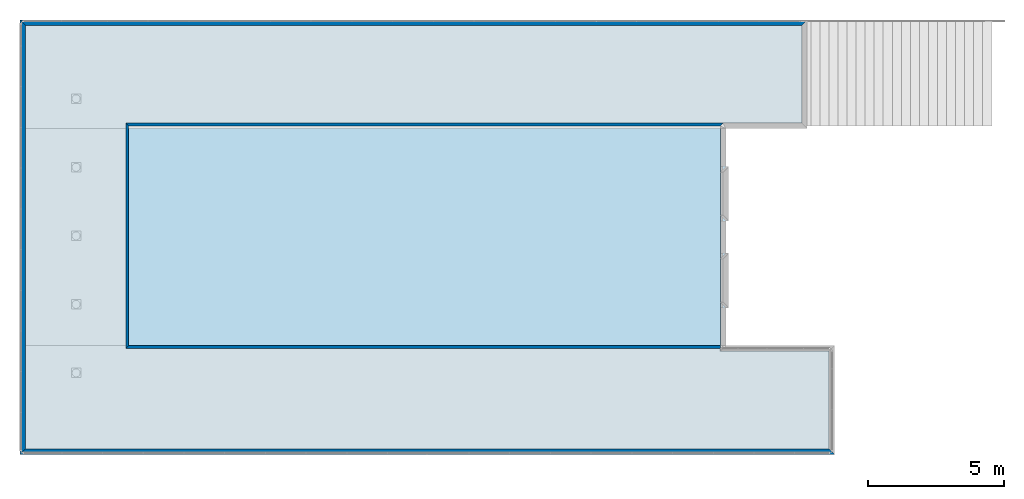
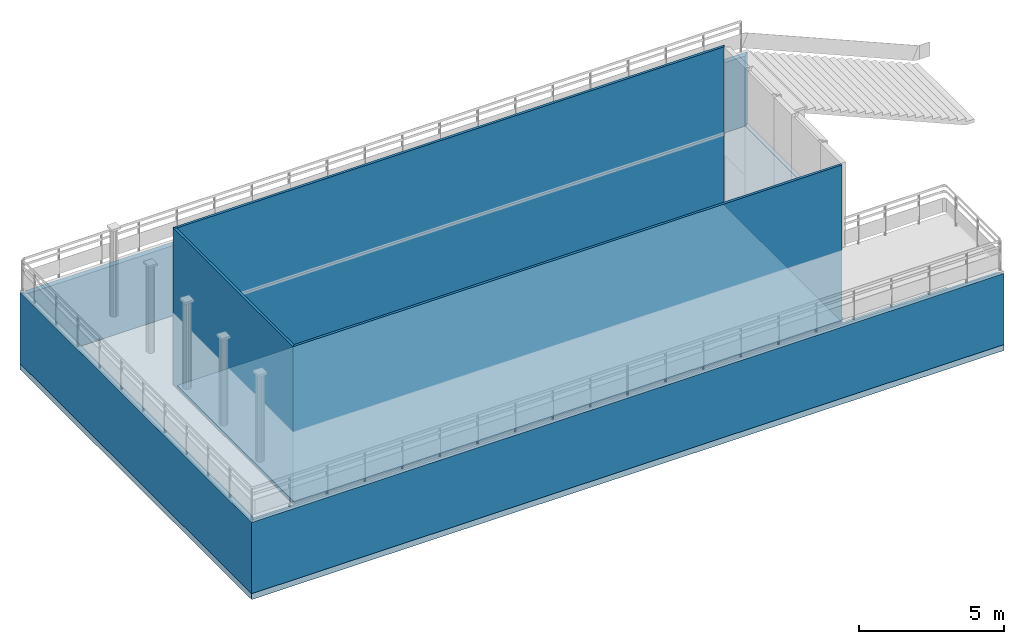
# One storey, part 1 of 54: 6 walls, 3 slabs.
"""IFC2X3 building model written with IfcOpenShell, lengths in metres."""

from ifc_helpers import new_model, entity, si_unit, converted_unit, derived_unit, frame, origin_with_axes, place, context, project, spatial, polyline, outline, extrude, material, layer, layer_set, layer_usage, element, save


model = new_model("IFC2X3")

# Units and contexts
context_of_model_1 = context(None, 3, world=origin_with_axes())
context_of_model_2 = context(None, 3, world=origin_with_axes())
context_of_model_3 = context(None, 2, world=origin_with_axes())
context_of_model_4 = context(None, 3, world=origin_with_axes())
ifc_project = project(units=[si_unit("LENGTHUNIT", "METRE"), si_unit("AREAUNIT", "SQUARE_METRE"), si_unit("ELECTRICCURRENTUNIT", "AMPERE"), si_unit("ELECTRICVOLTAGEUNIT", "VOLT"), si_unit("ELECTRICRESISTANCEUNIT", "OHM"), si_unit("POWERUNIT", "WATT"), si_unit("MASSUNIT", "GRAM"), si_unit("SOLIDANGLEUNIT", "STERADIAN"), si_unit("THERMODYNAMICTEMPERATUREUNIT", "KELVIN"), si_unit("PRESSUREUNIT", "PASCAL"), si_unit("LUMINOUSFLUXUNIT", "LUMEN"), si_unit("ILLUMINANCEUNIT", "LUX"), si_unit("FREQUENCYUNIT", "HERTZ"), si_unit("VOLUMEUNIT", "CUBIC_METRE"), si_unit("TIMEUNIT", "SECOND"), derived_unit("VOLUMETRICFLOWRATEUNIT", [(si_unit("TIMEUNIT", "SECOND"), -1), (si_unit("VOLUMEUNIT", "CUBIC_METRE"), 1)]), derived_unit("THERMALTRANSMITTANCEUNIT", [(si_unit("AREAUNIT", "SQUARE_METRE"), -1), (si_unit("THERMODYNAMICTEMPERATUREUNIT", "KELVIN"), -1), (si_unit("POWERUNIT", "WATT"), 1)]), converted_unit("PLANEANGLEUNIT", "DEGREE", entity("IfcPlaneAngleMeasure", 57.29577951308232), si_unit("PLANEANGLEUNIT", "RADIAN"), dimensions=[0, 0, 0, 0, 0, 0, 0])], contexts=[context_of_model_1, context_of_model_2, context_of_model_3, context_of_model_4])

# Site, building, storey
site = spatial("IfcSite", under=ifc_project, CompositionType="ELEMENT")
building_placement = place(None, origin_with_axes())
building = spatial("IfcBuilding", under=site, at=building_placement, Name="Tower", CompositionType="ELEMENT")
storey_placement = place(building_placement, frame((0.0, 0.0, 72.0), z_axis=(0.0, 0.0, 1.0), x_axis=(1.0, 0.0, 0.0)))
storey = spatial("IfcBuildingStorey", under=building, at=storey_placement, Name="Level 1", CompositionType="ELEMENT", Elevation=72.0)

# Slabs
ifc_material_1 = material(Name="Layer-n")
ifc_layer_1 = layer(ifc_material_1, 0.25, ventilated=False)
ifc_layer_set_1 = layer_set([ifc_layer_1])
ifc_layer_usage_1 = layer_usage(ifc_layer_set_1, "AXIS2", "POSITIVE", 0.0)
slab_1_placement = place(storey_placement, frame((-26.0, -4.0, 0.0), z_axis=(0.0, 0.0, 1.0), x_axis=(1.0, 0.0, 0.0)))
element("IfcSlab", 1, at=slab_1_placement, inside=storey, material=ifc_layer_usage_1, Name="n", PredefinedType="FLOOR", context=context_of_model_1, shape_type="SweptSolid", body=[
    extrude(outline(polyline([(0.0, 0.0), (30.0, 0.0), (30.0, 4.0), (26.0, 4.0), (26.0, 5.399999976158142), (26.10000000149012, 5.399999976158142), (26.10000000149012, 7.400000095367432), (26.0, 7.400000095367432), (26.0, 8.599999904632568), (26.10000000149012, 8.599999904632568), (26.10000000149012, 10.60000038146973), (26.0, 10.60000038146973), (26.0, 12.0), (29.0, 12.0), (29.0, 16.0), (0.0, 16.0), (0.0, 0.0)])), origin_with_axes(), (0.0, 0.0, -1.0), 0.25),
])
ifc_material_2 = material(Name="Layer-n")
ifc_layer_2 = layer(ifc_material_2, 0.25, ventilated=False)
ifc_layer_set_2 = layer_set([ifc_layer_2])
ifc_layer_usage_2 = layer_usage(ifc_layer_set_2, "AXIS2", "POSITIVE", 0.0)
slab_2_placement = place(storey_placement, frame((-0.2000000178813934, 8.09999942779541, 0.0), z_axis=(0.0, 0.0, 1.0), x_axis=(1.0, 0.0, 0.0)))
element("IfcSlab", 2, at=slab_2_placement, inside=storey, material=ifc_layer_usage_2, Name="n", PredefinedType="FLOOR", context=context_of_model_1, shape_type="SweptSolid", body=[
    extrude(outline(polyline([(0.0, 0.0), (21.79999998211869, 0.0), (21.80000069081223, 8.09999752044673), (9.322111264884415e-07, 8.099999427795295), (0.0, 0.0)])), frame((0.0, 0.0, 0.0), z_axis=(0.0, 0.0, 1.0), x_axis=(-0.9999999999999961, -8.749305662279772e-08, 0.0)), (0.0, 0.0, 1.0), 0.05000000074505806),
])
ifc_material_3 = material(Name="Layer-n")
ifc_layer_3 = layer(ifc_material_3, 0.25, ventilated=False)
ifc_layer_set_3 = layer_set([ifc_layer_3])
ifc_layer_usage_3 = layer_usage(ifc_layer_set_3, "AXIS2", "POSITIVE", 0.0)
slab_3_placement = place(storey_placement, frame((-25.79999923706055, -3.799999952316284, 0.0), z_axis=(0.0, 0.0, 1.0), x_axis=(1.0, 0.0, 0.0)))
element("IfcSlab", 3, at=slab_3_placement, inside=storey, material=ifc_layer_usage_3, Name="n", PredefinedType="FLOOR", context=context_of_model_1, shape_type="SweptSolid", body=[
    extrude(outline(polyline([(0.0, 0.0), (29.59999918937683, 0.0), (29.59999918937683, 3.599999949336052), (25.59999923408032, 3.599999949336052), (25.59999923408032, 3.699999950826168), (3.69999885559082, 3.699999950826168), (3.69999885559082, 11.99999785423279), (28.59999918937683, 11.99999976158142), (28.59999918937683, 15.60000014305115), (0.0, 15.60000014305115), (0.0, 0.0)])), origin_with_axes(), (0.0, 0.0, 1.0), 0.05000000074505806),
])

# Walls
ifc_material_4 = material()
ifc_layer_4 = layer(ifc_material_4, 0.1, ventilated=False)
ifc_layer_set_4 = layer_set([ifc_layer_4])
ifc_layer_usage_4 = layer_usage(ifc_layer_set_4, "AXIS2", "POSITIVE", 0.0)
wall_1_placement = place(storey_placement, frame((-0.1000003814697266, 8.199999809265137, 0.0), z_axis=(0.0, 0.0, 1.0), x_axis=(-1.0, -1.509958025280866e-07, 0.0)))
element("IfcWallStandardCase", 4, at=wall_1_placement, inside=storey, material=ifc_layer_usage_4, context=context_of_model_1, shape_type="SweptSolid", body=[
    extrude(outline(polyline([(0.0, 0.0), (22.00000000000009, 2.117582368135751e-22), (21.89999962720016, 0.1000003901395247), (0.0999996450814661, 0.1000003727999904), (0.0, 0.0)])), frame((0.0, 0.0, 0.0), z_axis=(0.0, 0.0, 1.0), x_axis=(0.9999999999999979, -6.42981340090188e-08, 0.0)), (0.0, 0.0, 1.0), 6.680000007152557),
])
wall_2_placement = place(storey_placement, frame((-22.10000038146973, 8.199997901916504, 0.0), z_axis=(0.0, 0.0, 1.0), x_axis=(-4.371138828673793e-08, -1.0, 0.0)))
element("IfcWallStandardCase", 5, at=wall_2_placement, inside=storey, material=ifc_layer_usage_4, context=context_of_model_1, shape_type="SweptSolid", body=[
    extrude(outline(polyline([(0.0, 0.0), (8.299997903406618, 0.0), (8.199997901916486, 0.1000003814697276), (0.1000003814697265, 0.1000003814697269), (0.0, 0.0)])), frame((0.0, 0.0, 0.0), z_axis=(0.0, 0.0, 1.0), x_axis=(0.9999999999999991, 4.371139008268922e-08, 0.0)), (0.0, 0.0, 1.0), 6.680000007152557),
])
wall_3_placement = place(storey_placement, frame((-22.10000038146973, -0.1000000014901161, 0.0), z_axis=(0.0, 0.0, 1.0), x_axis=(1.0, 0.0, 0.0)))
element("IfcWallStandardCase", 6, at=wall_3_placement, inside=storey, material=ifc_layer_usage_4, context=context_of_model_1, shape_type="SweptSolid", body=[
    extrude(outline(polyline([(0.0, 0.0), (21.90000037848949, 0.0), (21.90000014007092, 0.1000000014901802), (0.1000003814697266, 0.1000000014901321), (0.0, 0.0)])), origin_with_axes(), (0.0, 0.0, 1.0), 6.680000007152557),
])
ifc_material_5 = material(Name="Layer-Yttervegg 20.0cm")
ifc_layer_5 = layer(ifc_material_5, 0.2000000029802322, ventilated=False)
ifc_layer_set_5 = layer_set([ifc_layer_5], Name="ML-Yttervegg 20.0cm - 0.200")
ifc_layer_usage_5 = layer_usage(ifc_layer_set_5, "AXIS2", "POSITIVE", 0.0)
wall_4_placement = place(storey_placement, frame((-26.0, -4.0, 0.0), z_axis=(0.0, 0.0, 1.0), x_axis=(1.0, 0.0, 0.0)))
element("IfcWallStandardCase", 7, at=wall_4_placement, inside=storey, material=ifc_layer_usage_5, Name="Yttervegg 20.0cm", context=context_of_model_1, shape_type="SweptSolid", body=[
    extrude(outline(polyline([(0.0, 0.0), (30.0, 0.0), (29.79999995231628, 0.2000000476837158), (0.2000007629394531, 0.2000000476837158), (0.0, 0.0)])), origin_with_axes(), (0.0, 0.0, 1.0), 3.0),
])
wall_5_placement = place(storey_placement, frame((3.0, 12.0, 0.0), z_axis=(0.0, 0.0, 1.0), x_axis=(-1.0, -8.742277657347586e-08, 0.0)))
element("IfcWallStandardCase", 8, at=wall_5_placement, inside=storey, material=ifc_layer_usage_5, Name="Yttervegg 20.0cm", context=context_of_model_1, shape_type="SweptSolid", body=[
    extrude(outline(polyline([(0.0, 0.0), (28.99999999999999, 0.0), (28.79999923706055, 0.1999998092651348), (0.200000047683716, 0.1999998092651345), (0.0, 0.0)])), frame((0.0, 0.0, 0.0), z_axis=(0.0, 0.0, 1.0), x_axis=(0.9999999999999962, -8.742278000368218e-08, 0.0)), (0.0, 0.0, 1.0), 3.0),
])
wall_6_placement = place(storey_placement, frame((-26.0, 12.0, 0.0), z_axis=(0.0, 0.0, 1.0), x_axis=(-4.371138828673793e-08, -1.0, 0.0)))
element("IfcWallStandardCase", 9, at=wall_6_placement, inside=storey, material=ifc_layer_usage_5, Name="Yttervegg 20.0cm", context=context_of_model_1, shape_type="SweptSolid", body=[
    extrude(outline(polyline([(0.0, 0.0), (16.0, 0.0), (15.79999995231628, 0.2000007629394537), (0.1999998092651365, 0.2000007629394528), (0.0, 0.0)])), frame((0.0, 0.0, 0.0), z_axis=(0.0, 0.0, 1.0), x_axis=(0.9999999999999991, 4.371139006309478e-08, 0.0)), (0.0, 0.0, 1.0), 3.0),
])

save(model, "model.ifc")
